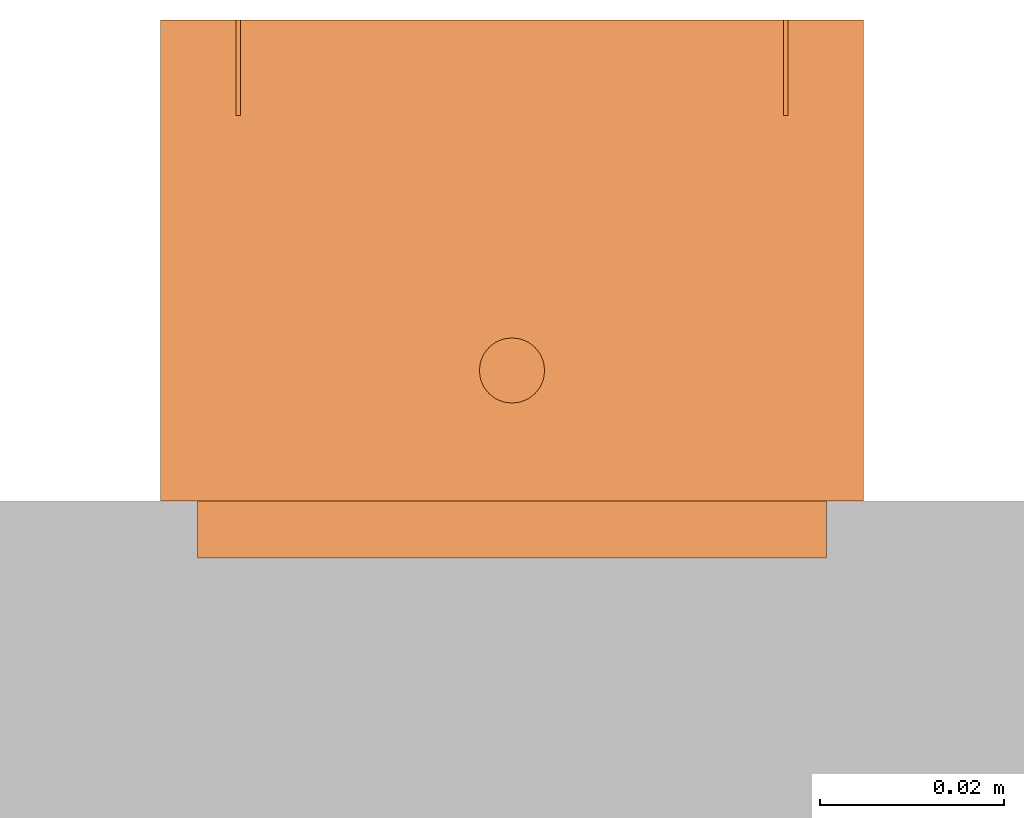
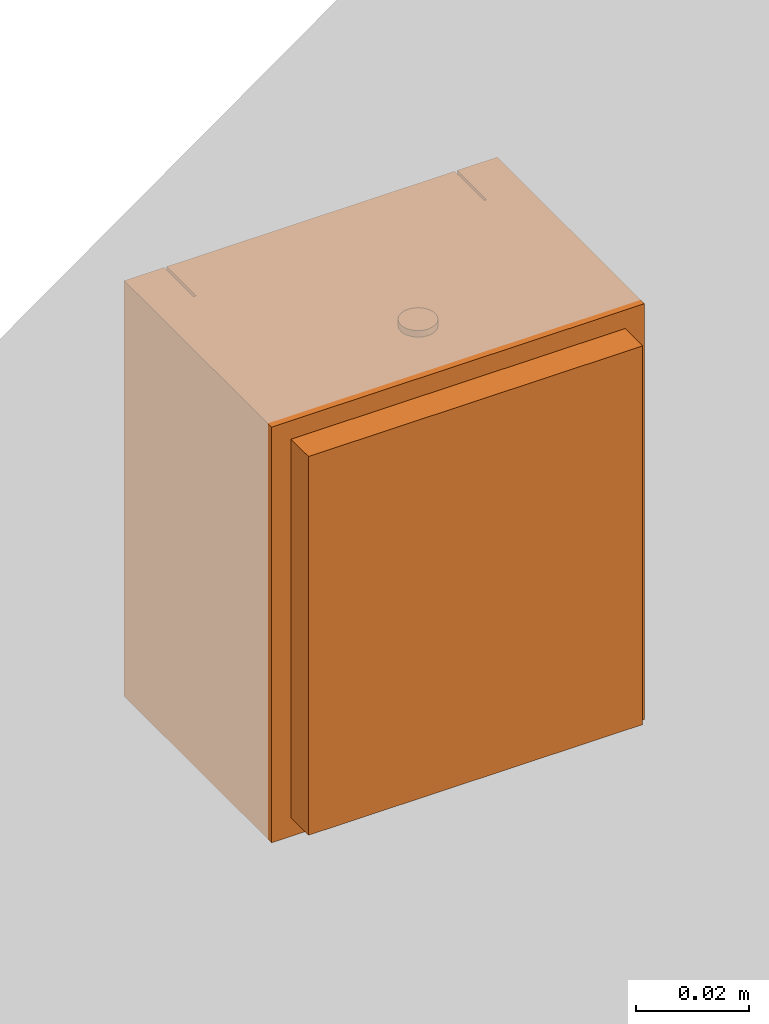
# One storey, part 2 of 2: 1 proxy.
"""IFC2X3 building model written with IfcOpenShell, lengths in millimetres."""

from ifc_helpers import new_model, entity, si_unit, converted_unit, derived_unit, direction, frame, origin, place, context, subcontext, project, spatial, faceted_brep, source, transform, mapped, material, type_object, type_shapes, element, save


model = new_model("IFC2X3")

# Units and contexts
model_context = context("Model", 3, precision=0.01, world=origin(), true_north=direction((6.12303176911189e-17, 1.0)))
body_context = subcontext(model_context, "Body", "Model", "MODEL_VIEW")
ifc_project = project(units=[si_unit("LENGTHUNIT", "METRE", prefix="MILLI"), si_unit("AREAUNIT", "SQUARE_METRE"), si_unit("VOLUMEUNIT", "CUBIC_METRE"), converted_unit("PLANEANGLEUNIT", "DEGREE", entity("IfcRatioMeasure", 0.0174532925199433), si_unit("PLANEANGLEUNIT", "RADIAN"), dimensions=[0, 0, 0, 0, 0, 0, 0]), si_unit("MASSUNIT", "GRAM", prefix="KILO"), derived_unit("MASSDENSITYUNIT", [(si_unit("MASSUNIT", "GRAM", prefix="KILO"), 1), (si_unit("LENGTHUNIT", "METRE"), -3)]), si_unit("TIMEUNIT", "SECOND"), si_unit("FREQUENCYUNIT", "HERTZ"), si_unit("THERMODYNAMICTEMPERATUREUNIT", "DEGREE_CELSIUS"), derived_unit("THERMALTRANSMITTANCEUNIT", [(si_unit("MASSUNIT", "GRAM", prefix="KILO"), 1), (si_unit("THERMODYNAMICTEMPERATUREUNIT", "KELVIN"), -1), (si_unit("TIMEUNIT", "SECOND"), -3)]), derived_unit("VOLUMETRICFLOWRATEUNIT", [(si_unit("LENGTHUNIT", "METRE"), 3), (si_unit("TIMEUNIT", "SECOND"), -1)]), si_unit("ELECTRICCURRENTUNIT", "AMPERE"), si_unit("ELECTRICVOLTAGEUNIT", "VOLT"), si_unit("POWERUNIT", "WATT"), si_unit("FORCEUNIT", "NEWTON", prefix="KILO"), si_unit("ILLUMINANCEUNIT", "LUX"), si_unit("LUMINOUSFLUXUNIT", "LUMEN"), si_unit("LUMINOUSINTENSITYUNIT", "CANDELA"), derived_unit("USERDEFINED", [(si_unit("MASSUNIT", "GRAM", prefix="KILO"), -1), (si_unit("LENGTHUNIT", "METRE"), -2), (si_unit("TIMEUNIT", "SECOND"), 3), (si_unit("LUMINOUSFLUXUNIT", "LUMEN"), 1)]), derived_unit("LINEARVELOCITYUNIT", [(si_unit("LENGTHUNIT", "METRE"), 1), (si_unit("TIMEUNIT", "SECOND"), -1)]), si_unit("PRESSUREUNIT", "PASCAL"), derived_unit("USERDEFINED", [(si_unit("LENGTHUNIT", "METRE"), -2), (si_unit("MASSUNIT", "GRAM", prefix="KILO"), 1), (si_unit("TIMEUNIT", "SECOND"), -2)])], contexts=[model_context])

# Site, building, storey
site_placement = place(None, origin())
site = spatial("IfcSite", under=ifc_project, at=site_placement, CompositionType="ELEMENT")
building_placement = place(site_placement, origin())
building = spatial("IfcBuilding", under=site, at=building_placement, CompositionType="ELEMENT")
storey_placement = place(building_placement, origin())
storey = spatial("IfcBuildingStorey", under=building, at=storey_placement, Name="Ebene 1", CompositionType="ELEMENT", Elevation=0.0)

# Proxy
ifc_material = material(Name="White")
building_element_proxy_type = type_object("IfcBuildingElementProxyType", PredefinedType="NOTDEFINED", material=ifc_material)
shared_shape = source(origin(), body_context, "Body", "Brep", [
    faceted_brep([(67.7, 48.0999999999999, 9.09999999999752), (67.7, 58.1, 10.8632698070822), (67.7, 53.9146115753526, 70.7171128226717), (67.7, 48.1, 72.0999999999975), (8.70000000000002, 48.0999999999999, 9.09999999999752), (8.70000000000002, 48.1, 72.0999999999975), (8.70000000000002, 53.9146115753526, 70.7171128226717), (8.70000000000002, 58.1, 10.8632698070822)], [[[0, 1, 2, 3]], [[4, 5, 6, 7]], [[1, 0, 4, 7]], [[2, 1, 7, 6]], [[3, 2, 6, 5]], [[0, 3, 5, 4]]]),
    faceted_brep([(41.9, 57.3671158199917, 39.0), (34.4999999999999, 57.3671158199917, 39.0), (32.1999999999999, 57.3671158199917, 41.3), (34.4999999999999, 57.3671158199917, 43.6), (41.9, 57.3671158199917, 43.6), (44.2, 57.3671158199917, 41.3), (41.9, 48.1, 43.6), (34.4999999999999, 48.1, 43.6), (32.1999999999999, 48.1, 41.3), (34.4999999999999, 48.1, 39.0), (41.9, 48.1, 39.0), (44.2, 48.1, 41.3)], [[[0, 1, 2, 3, 4, 5]], [[6, 7, 8, 9, 10, 11]], [[7, 3, 2, 8]], [[2, 1, 9, 8]], [[10, 9, 1, 0]], [[10, 0, 5, 11]], [[5, 4, 6, 11]], [[7, 6, 4, 3]]]),
    faceted_brep([(76.4000000000001, 58.5, 90.0), (76.4000000000001, 58.5, 0.0), (0.0, 58.5, 0.0), (0.0, 58.5, 90.0), (8.20000000000001, 58.5, 90.0), (8.20000000000001, 58.5, 8.60000000000002), (68.2, 58.5, 8.60000000000001), (68.2, 58.5, 90.0), (0.0, 6.20000000000001, 90.0), (0.0, 6.20000000000001, 0.0), (76.4000000000001, 6.20000000000001, 0.0), (76.4000000000001, 6.20000000000001, 90.0), (68.2, 48.1, 90.0), (8.20000000000001, 48.1, 90.0), (68.2, 48.1, 8.60000000000001), (8.20000000000001, 48.1, 8.60000000000002)], [[[0, 1, 2, 3, 4, 5, 6, 7]], [[8, 9, 10, 11]], [[3, 2, 9, 8]], [[2, 1, 10, 9]], [[1, 0, 11, 10]], [[8, 11, 0, 7, 12, 13, 4, 3]], [[14, 15, 13, 12]], [[13, 15, 5, 4]], [[15, 14, 6, 5]], [[14, 12, 7, 6]]]),
    faceted_brep([(67.7, 48.1, 85.0), (8.70000000000002, 48.1, 85.0), (8.70000000000002, 48.1, 72.0), (67.7, 48.1, 72.0), (67.7, 58.5, 85.0), (67.7, 58.5, 72.0), (8.70000000000002, 58.5, 72.0), (8.70000000000002, 58.5, 85.0)], [[[0, 1, 2, 3]], [[4, 5, 6, 7]], [[2, 1, 7, 6]], [[0, 3, 5, 4]], [[1, 0, 4, 7]], [[3, 2, 6, 5]]]),
    faceted_brep([(8.70000000000002, 48.1, 90.0), (8.70000000000002, 48.1, 85.5), (67.7, 48.1, 85.5), (67.7, 48.1, 90.0), (8.70000000000002, 58.5, 90.0), (67.7, 58.5, 90.0), (67.7, 58.5, 85.5), (8.70000000000002, 58.5, 85.5)], [[[0, 1, 2, 3]], [[4, 5, 6, 7]], [[1, 0, 4, 7]], [[2, 1, 7, 6]], [[3, 2, 6, 5]], [[0, 3, 5, 4]]]),
    faceted_brep([(41.6290366833266, 19.4811923898861, 91.4), (41.7500000000004, 20.4, 91.4), (41.6290366833266, 21.318807610114, 91.4), (41.2743901834352, 22.175, 91.4), (40.7102290732127, 22.9102290732123, 91.4), (39.9750000000004, 23.4743901834348, 91.4), (39.1188076101144, 23.8290366833262, 91.4), (38.2000000000004, 23.95, 91.4), (37.2811923898865, 23.8290366833262, 91.4), (36.4250000000004, 23.4743901834348, 91.4), (35.6897709267882, 22.9102290732123, 91.4), (35.1256098165657, 22.175, 91.4), (34.7709633166742, 21.318807610114, 91.4), (34.6500000000004, 20.4, 91.4), (34.7709633166742, 19.4811923898861, 91.4), (35.1256098165656, 18.625, 91.4), (35.6897709267882, 17.8897709267878, 91.4), (36.4250000000004, 17.3256098165653, 91.4), (37.2811923898864, 16.9709633166738, 91.4), (38.2000000000004, 16.85, 91.4), (39.1188076101144, 16.9709633166738, 91.4), (39.9750000000004, 17.3256098165653, 91.4), (40.7102290732127, 17.8897709267878, 91.4), (41.2743901834352, 18.625, 91.4), (38.2000000000004, 23.95, 90.0), (39.1188076101144, 23.8290366833262, 90.0), (39.9750000000004, 23.4743901834348, 90.0), (40.7102290732127, 22.9102290732123, 90.0), (41.2743901834352, 22.175, 90.0), (41.6290366833266, 21.318807610114, 90.0), (41.7500000000004, 20.4, 90.0), (41.6290366833266, 19.4811923898861, 90.0), (41.2743901834352, 18.625, 90.0), (40.7102290732127, 17.8897709267878, 90.0), (39.9750000000004, 17.3256098165653, 90.0), (39.1188076101144, 16.9709633166738, 90.0), (38.2000000000004, 16.85, 90.0), (37.2811923898864, 16.9709633166738, 90.0), (36.4250000000004, 17.3256098165653, 90.0), (35.6897709267882, 17.8897709267878, 90.0), (35.1256098165656, 18.625, 90.0), (34.7709633166742, 19.4811923898861, 90.0), (34.6500000000004, 20.4, 90.0), (34.7709633166742, 21.318807610114, 90.0), (35.1256098165657, 22.175, 90.0), (35.6897709267882, 22.9102290732123, 90.0), (36.4250000000004, 23.4743901834348, 90.0), (37.2811923898865, 23.8290366833262, 90.0)], [[[0, 1, 2, 3, 4, 5, 6, 7, 8, 9, 10, 11, 12, 13, 14, 15, 16, 17, 18, 19, 20, 21, 22, 23]], [[24, 25, 26, 27, 28, 29, 30, 31, 32, 33, 34, 35, 36, 37, 38, 39, 40, 41, 42, 43, 44, 45, 46, 47]], [[41, 14, 13, 42]], [[40, 15, 14, 41]], [[17, 16, 39, 38]], [[40, 39, 16, 15]], [[18, 17, 38, 37]], [[19, 18, 37, 36]], [[35, 20, 19, 36]], [[34, 21, 20, 35]], [[23, 22, 33, 32]], [[34, 33, 22, 21]], [[0, 23, 32, 31]], [[1, 0, 31, 30]], [[29, 2, 1, 30]], [[28, 3, 2, 29]], [[5, 4, 27, 26]], [[28, 27, 4, 3]], [[6, 5, 26, 25]], [[7, 6, 25, 24]], [[47, 8, 7, 24]], [[46, 9, 8, 47]], [[11, 10, 45, 44]], [[46, 45, 10, 9]], [[12, 11, 44, 43]], [[13, 12, 43, 42]]]),
    faceted_brep([(4.0, 0.0, 86.0), (4.0, 0.0, 4.0), (72.4000000000001, 0.0, 4.0), (72.4000000000001, 0.0, 86.0), (4.0, 6.20000000000001, 86.0), (72.4000000000001, 6.20000000000001, 86.0), (72.4000000000001, 6.20000000000001, 4.0), (4.0, 6.20000000000001, 4.0)], [[[0, 1, 2, 3]], [[4, 5, 6, 7]], [[1, 0, 4, 7]], [[2, 1, 7, 6]], [[3, 2, 6, 5]], [[0, 3, 5, 4]]]),
])
type_shapes(building_element_proxy_type, [shared_shape])
proxy_placement = place(storey_placement, frame((4296.76456477082, 3494.98432304186, 1988.28426738753)))
element("IfcBuildingElementProxy", 1, at=proxy_placement, inside=storey, type_object=building_element_proxy_type, material=ifc_material, context=body_context, shape_type="MappedRepresentation", body=[
    mapped(shared_shape, transform((0.0, 0.0, 0.0), scale=1.0)),
])

save(model, "model.ifc")
